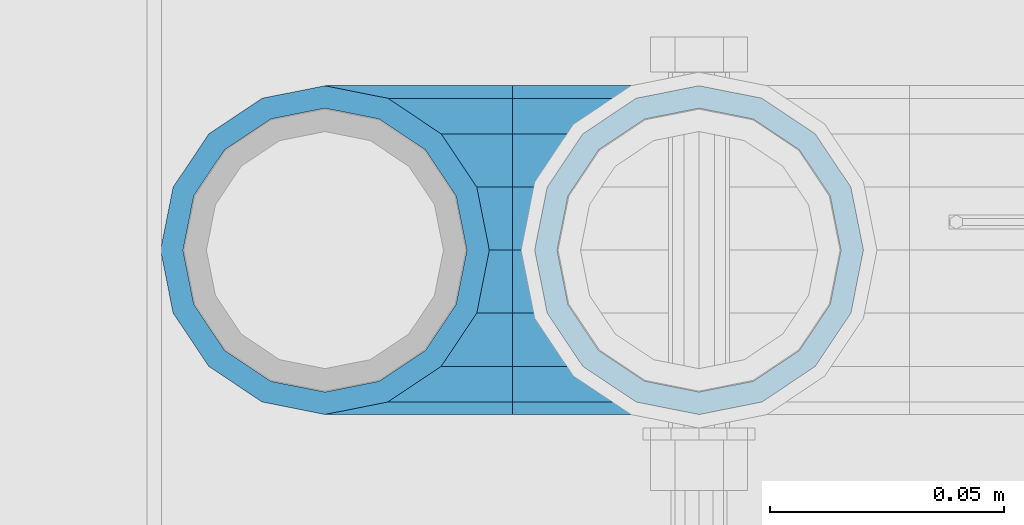
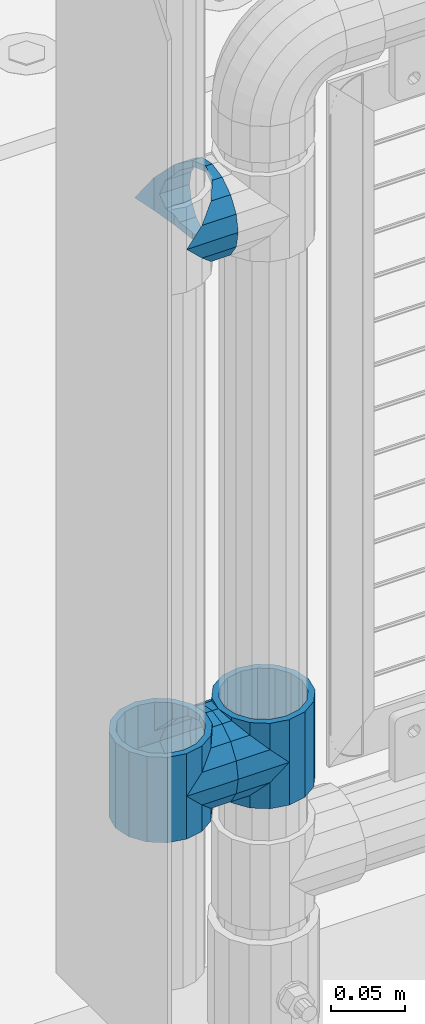
# One storey, part 158 of 270: 5 beams.
"""IFC2X3 building model written with IfcOpenShell, lengths in millimetres."""

from ifc_helpers import new_model, si_unit, frame, origin_with_axes, place, context, subcontext, project, spatial, faceted_brep, material, type_object, element, save


model = new_model("IFC2X3")

# Units and contexts
model_context = context("Model", 3, precision=1e-05, world=origin_with_axes())
body_context = subcontext(model_context, "Body", "Model", "MODEL_VIEW")
ifc_project = project(units=[si_unit("LENGTHUNIT", "METRE", prefix="MILLI"), si_unit("AREAUNIT", "SQUARE_METRE"), si_unit("VOLUMEUNIT", "CUBIC_METRE"), si_unit("MASSUNIT", "GRAM", prefix="KILO"), si_unit("TIMEUNIT", "SECOND"), si_unit("PLANEANGLEUNIT", "RADIAN"), si_unit("SOLIDANGLEUNIT", "STERADIAN"), si_unit("THERMODYNAMICTEMPERATUREUNIT", "DEGREE_CELSIUS"), si_unit("LUMINOUSINTENSITYUNIT", "LUMEN")], contexts=[model_context])

# Site, building, storey
site_placement = place(None, origin_with_axes())
site = spatial("IfcSite", under=ifc_project, at=site_placement, CompositionType="ELEMENT")
building_placement = place(site_placement, origin_with_axes())
building = spatial("IfcBuilding", under=site, at=building_placement, Name="Standard", CompositionType="ELEMENT")
storey_placement = place(building_placement, origin_with_axes())
storey = spatial("IfcBuildingStorey", under=building, at=storey_placement, Name="Undefined", CompositionType="ELEMENT", Elevation=0.0)

# Beams
ifc_material = material(Name="Misc_Undefined")
beam_type = type_object("IfcBeamType", PredefinedType="NOTDEFINED")
beam_1_placement = place(storey_placement, frame((541.0, -16335.5, 398.67), z_axis=(0.0, -1.0, 0.0), x_axis=(1.0, 0.0, 0.0)))
element("IfcBeam", 1, at=beam_1_placement, inside=storey, type_object=beam_type, material=ifc_material, context=body_context, shape_type="Brep", body=[
    faceted_brep([(0.0, 0.0, -35.1499999999996), (13.4513226476338, -13.4513226476329, -32.4743655677721), (13.4513226476338, 13.4513226476329, -32.4743655677721), (32.4743655677703, 32.4743655677717, 13.4513226476338), (32.4743655677703, 26.8123795176776, 13.4513226476338), (27.1226768591041, 21.4606908090117, 21.4606908090118), (24.8548033587067, 16.3810424080045, 24.8548033587067), (24.8548033587067, 24.8548033587072, 24.8548033587067), (13.4513226476338, 13.4513226476329, 32.4743655677721), (13.4513226476338, -13.4513226476329, 32.4743655677721), (0.0, 0.0, 35.1499999999996), (20.0882031229812, 11.6144421722805, 28.0397438117179), (16.6306603983612, 0.0, 30.3500000000004), (20.0882031229812, -11.6144421722805, 28.0397438117179), (24.8548033587067, -16.3810424080045, 24.8548033587067), (24.8548033587067, -24.8548033587072, 24.8548033587067), (32.4743655677703, -26.8123795176775, 13.4513226476338), (32.4743655677703, -32.4743655677717, 13.4513226476338), (27.1226768591041, -21.4606908090117, 21.4606908090118), (35.1500000000015, -30.35, 0.0), (35.1500000000015, -35.15, 0.0), (32.8397438117208, -28.0397438117175, 11.6144421722802), (32.8397438117172, -28.0397438117175, -11.6144421722802), (32.4743655677703, -26.8123795176776, -13.4513226476338), (32.4743655677703, -32.4743655677717, -13.4513226476338), (27.1226768591041, -21.4606908090117, -21.4606908090118), (24.8548033587067, -16.3810424080045, -24.8548033587067), (24.8548033587067, -24.8548033587072, -24.8548033587067), (20.0882031229849, -11.6144421722805, -28.0397438117179), (16.6306603983721, 0.0, -30.3500000000004), (20.0882031229849, 11.6144421722805, -28.0397438117179), (24.8548033587067, 16.3810424080045, -24.8548033587067), (24.8548033587067, 24.8548033587072, -24.8548033587067), (27.1226768591041, 21.4606908090117, -21.4606908090118), (32.4743655677703, 26.8123795176775, -13.4513226476338), (32.4743655677703, 32.4743655677717, -13.4513226476338), (32.8397438117172, 28.0397438117175, -11.6144421722802), (35.1500000000015, 30.35, 0.0), (35.1500000000015, 35.1500000000003, 0.0), (32.8397438117208, 28.0397438117175, 11.6144421722802), (40.1500000000015, -35.15, 0.0), (40.1500000000015, -32.4743655677717, 13.4513226476338), (40.1500000000015, -24.8548033587072, 24.8548033587067), (40.1500000000015, -13.4513226476329, 32.4743655677721), (40.1500000000015, 0.0, 35.1499999999996), (40.1500000000015, 13.4513226476329, 32.4743655677721), (40.1500000000015, 24.8548033587072, 24.8548033587067), (40.1500000000015, 32.4743655677717, 13.4513226476338), (40.1500000000015, 35.15, 0.0), (40.1500000000015, -24.8548033587072, -24.8548033587067), (40.1500000000015, -32.4743655677717, -13.4513226476338), (40.1500000000015, -13.4513226476329, -32.4743655677721), (40.1500000000015, 0.0, -35.1499999999996), (40.1500000000015, 13.4513226476329, -32.4743655677721), (40.1500000000015, 24.8548033587072, -24.8548033587067), (40.1500000000015, 32.4743655677717, -13.4513226476338), (40.1500000000015, -21.4606908090117, 21.4606908090118), (40.1500000000015, -11.6144421722805, 28.0397438117179), (40.1500000000015, 0.0, 30.3500000000004), (40.1500000000015, 11.6144421722805, 28.0397438117179), (40.1500000000015, 21.4606908090117, 21.4606908090118), (40.1500000000015, 28.0397438117175, 11.6144421722802), (40.1500000000015, 30.35, 0.0), (40.1500000000015, 28.0397438117175, -11.6144421722802), (40.1500000000015, 21.4606908090117, -21.4606908090118), (40.1500000000015, 11.6144421722805, -28.0397438117179), (40.1500000000015, 0.0, -30.3500000000004), (40.1500000000015, -11.6144421722805, -28.0397438117179), (40.1500000000015, -21.4606908090117, -21.4606908090118), (40.1500000000015, -28.0397438117175, -11.6144421722802), (40.1500000000015, -30.35, 0.0), (40.1500000000015, -28.0397438117175, 11.6144421722802)], [[[0, 1, 2]], [[3, 4, 5, 6, 7]], [[8, 9, 10]], [[7, 6, 11, 12, 13, 14, 15, 9, 8]], [[16, 17, 15, 14, 18]], [[19, 20, 17, 16, 21]], [[22, 23, 24, 20, 19]], [[25, 26, 27, 24, 23]], [[2, 1, 27, 26, 28, 29, 30, 31, 32]], [[32, 31, 33, 34, 35]], [[35, 34, 36, 37, 38]], [[38, 37, 39, 4, 3]], [[40, 41, 17, 20]], [[41, 42, 15, 17]], [[42, 43, 9, 15]], [[43, 44, 10, 9]], [[44, 45, 8, 10]], [[45, 46, 7, 8]], [[46, 47, 3, 7]], [[47, 48, 38, 3]], [[49, 50, 24, 27]], [[51, 49, 27, 1]], [[52, 51, 1, 0]], [[53, 52, 0, 2]], [[54, 53, 2, 32]], [[55, 54, 32, 35]], [[48, 55, 35, 38]], [[50, 40, 20, 24]], [[49, 51, 52, 53, 54, 55, 48, 47, 46, 45, 44, 43, 42, 41, 40, 50], [56, 57, 58, 59, 60, 61, 62, 63, 64, 65, 66, 67, 68, 69, 70, 71]], [[63, 62, 37, 36]], [[33, 64, 63, 36, 34]], [[30, 65, 64, 33, 31]], [[66, 65, 30, 29]], [[67, 66, 29, 28]], [[68, 67, 28, 26, 25]], [[69, 68, 25, 23, 22]], [[70, 69, 22, 19]], [[71, 70, 19, 21]], [[18, 56, 71, 21, 16]], [[13, 57, 56, 18, 14]], [[58, 57, 13, 12]], [[59, 58, 12, 11]], [[60, 59, 11, 6, 5]], [[61, 60, 5, 4, 39]], [[62, 61, 39, 37]]]),
])
beam_2_placement = place(storey_placement, frame((621.0, -16335.5, 398.67), z_axis=(0.0, 1.0, 0.0), x_axis=(-1.0, 0.0, 0.0)))
element("IfcBeam", 2, at=beam_2_placement, inside=storey, type_object=beam_type, material=ifc_material, context=body_context, shape_type="Brep", body=[
    faceted_brep([(0.0, 0.0, -35.1499999999996), (13.4513226476338, -13.4513226476329, -32.4743655677721), (13.4513226476338, 13.4513226476329, -32.4743655677721), (32.4743655677703, -26.8123795176775, 13.4513226476338), (32.4743655677703, -32.4743655677717, 13.4513226476338), (24.8548033587067, -24.8548033587072, 24.8548033587067), (24.8548033587067, -16.3810424080045, 24.8548033587067), (27.1226768591041, -21.4606908090117, 21.4606908090118), (35.1500000000015, -30.35, 0.0), (35.1500000000015, -35.15, 0.0), (32.8397438117208, -28.0397438117175, 11.6144421722802), (32.8397438117172, -28.0397438117175, -11.6144421722802), (32.4743655677703, -26.8123795176776, -13.4513226476338), (32.4743655677703, -32.4743655677717, -13.4513226476338), (27.1226768591041, -21.4606908090117, -21.4606908090118), (24.8548033587067, -16.3810424080045, -24.8548033587067), (24.8548033587067, -24.8548033587072, -24.8548033587067), (20.0882031229849, -11.6144421722805, -28.0397438117179), (16.6306603983721, 0.0, -30.3500000000004), (20.0882031229849, 11.6144421722805, -28.0397438117179), (24.8548033587067, 16.3810424080045, -24.8548033587067), (24.8548033587067, 24.8548033587072, -24.8548033587067), (27.1226768591041, 21.4606908090117, -21.4606908090118), (32.4743655677703, 26.8123795176775, -13.4513226476338), (32.4743655677703, 32.4743655677717, -13.4513226476338), (32.8397438117172, 28.0397438117175, -11.6144421722802), (35.1500000000015, 30.35, 0.0), (35.1500000000015, 35.1500000000003, 0.0), (32.8397438117208, 28.0397438117175, 11.6144421722802), (32.4743655677703, 26.8123795176776, 13.4513226476338), (32.4743655677703, 32.4743655677717, 13.4513226476338), (27.1226768591041, 21.4606908090117, 21.4606908090118), (24.8548033587067, 16.3810424080045, 24.8548033587067), (24.8548033587067, 24.8548033587072, 24.8548033587067), (13.4513226476338, 13.4513226476329, 32.4743655677721), (13.4513226476338, -13.4513226476329, 32.4743655677721), (0.0, 0.0, 35.1499999999996), (20.0882031229812, 11.6144421722805, 28.0397438117179), (16.6306603983612, 0.0, 30.3500000000004), (20.0882031229812, -11.6144421722805, 28.0397438117179), (40.1500000000015, -35.15, 0.0), (40.1500000000015, -32.4743655677717, 13.4513226476338), (40.1500000000015, -24.8548033587072, 24.8548033587067), (40.1500000000015, -13.4513226476329, 32.4743655677721), (40.1500000000015, 0.0, 35.1499999999996), (40.1500000000015, -24.8548033587072, -24.8548033587067), (40.1500000000015, -32.4743655677717, -13.4513226476338), (40.1500000000015, -13.4513226476329, -32.4743655677721), (40.1500000000015, 0.0, -35.1499999999996), (40.1500000000015, 13.4513226476329, -32.4743655677721), (40.1500000000015, 24.8548033587072, -24.8548033587067), (40.1500000000015, 32.4743655677717, -13.4513226476338), (40.1500000000015, 35.15, 0.0), (40.1500000000015, 32.4743655677717, 13.4513226476338), (40.1500000000015, 24.8548033587072, 24.8548033587067), (40.1500000000015, 13.4513226476329, 32.4743655677721), (40.1500000000015, -21.4606908090117, 21.4606908090118), (40.1500000000015, -11.6144421722805, 28.0397438117179), (40.1500000000015, 0.0, 30.3500000000004), (40.1500000000015, 11.6144421722805, 28.0397438117179), (40.1500000000015, 21.4606908090117, 21.4606908090118), (40.1500000000015, 28.0397438117175, 11.6144421722802), (40.1500000000015, 30.35, 0.0), (40.1500000000015, 28.0397438117175, -11.6144421722802), (40.1500000000015, 21.4606908090117, -21.4606908090118), (40.1500000000015, 11.6144421722805, -28.0397438117179), (40.1500000000015, 0.0, -30.3500000000004), (40.1500000000015, -11.6144421722805, -28.0397438117179), (40.1500000000015, -21.4606908090117, -21.4606908090118), (40.1500000000015, -28.0397438117175, -11.6144421722802), (40.1500000000015, -30.35, 0.0), (40.1500000000015, -28.0397438117175, 11.6144421722802)], [[[0, 1, 2]], [[3, 4, 5, 6, 7]], [[8, 9, 4, 3, 10]], [[11, 12, 13, 9, 8]], [[14, 15, 16, 13, 12]], [[2, 1, 16, 15, 17, 18, 19, 20, 21]], [[21, 20, 22, 23, 24]], [[24, 23, 25, 26, 27]], [[27, 26, 28, 29, 30]], [[30, 29, 31, 32, 33]], [[34, 35, 36]], [[33, 32, 37, 38, 39, 6, 5, 35, 34]], [[40, 41, 4, 9]], [[41, 42, 5, 4]], [[42, 43, 35, 5]], [[43, 44, 36, 35]], [[45, 46, 13, 16]], [[47, 45, 16, 1]], [[48, 47, 1, 0]], [[49, 48, 0, 2]], [[50, 49, 2, 21]], [[51, 50, 21, 24]], [[52, 51, 24, 27]], [[53, 52, 27, 30]], [[54, 53, 30, 33]], [[55, 54, 33, 34]], [[44, 55, 34, 36]], [[46, 40, 9, 13]], [[45, 47, 48, 49, 50, 51, 52, 53, 54, 55, 44, 43, 42, 41, 40, 46], [56, 57, 58, 59, 60, 61, 62, 63, 64, 65, 66, 67, 68, 69, 70, 71]], [[59, 58, 38, 37]], [[60, 59, 37, 32, 31]], [[61, 60, 31, 29, 28]], [[62, 61, 28, 26]], [[63, 62, 26, 25]], [[22, 64, 63, 25, 23]], [[19, 65, 64, 22, 20]], [[66, 65, 19, 18]], [[67, 66, 18, 17]], [[68, 67, 17, 15, 14]], [[69, 68, 14, 12, 11]], [[70, 69, 11, 8]], [[71, 70, 8, 10]], [[7, 56, 71, 10, 3]], [[39, 57, 56, 7, 6]], [[58, 57, 39, 38]]]),
])
beam_3_placement = place(storey_placement, frame((541.0, -16335.5, 433.819999999999), z_axis=(-1.0, 0.0, 0.0), x_axis=(0.0, 0.0, -1.0)))
element("IfcBeam", 3, at=beam_3_placement, inside=storey, type_object=beam_type, material=ifc_material, context=body_context, shape_type="Brep", body=[
    faceted_brep([(7.11025618828319, -11.6144421722802, -32.8397438117172), (7.11025618828319, -11.6144421722802, -28.0397438117179), (13.689309190989, -21.4606908090118, -21.46069080901), (13.689309190989, -21.4606908090118, -27.1226768591041), (8.33762048232484, -13.4513226476338, -32.4743655677703), (23.5355578277203, -28.0397438117179, -11.614442172282), (23.5355578277203, -28.0397438117179, -20.0882031229885), (18.7689575919954, -24.8548033587067, -24.8548033587067), (35.1500000000015, -30.35, 0.0), (35.1500000000008, -30.3500000000004, -16.6306603983721), (46.7644421722812, -28.0397438117179, -11.614442172282), (46.7644421722812, -28.0397438117179, -20.0882031229885), (51.5310424080071, -24.8548033587067, -24.8548033587067), (56.6106908090125, -21.4606908090118, -21.46069080901), (56.6106908090125, -21.4606908090118, -27.1226768591041), (61.9623795176767, -13.4513226476338, -32.4743655677703), (63.1897438117183, -11.6144421722802, -28.0397438117179), (63.1897438117183, -11.6144421722802, -32.8397438117172), (65.5000000000008, 0.0, -30.3499999999985), (65.5000000000008, 0.0, -35.1500000000015), (63.1897438117183, 11.6144421722802, -28.0397438117179), (63.1897438117183, 11.6144421722802, -32.8397438117208), (56.6106908090125, 21.4606908090118, -21.46069080901), (56.6106908090125, 21.4606908090118, -27.1226768591005), (61.9623795176767, 13.4513226476338, -32.4743655677703), (46.7644421722812, 28.0397438117179, -11.614442172282), (46.7644421722812, 28.0397438117179, -20.0882031229812), (51.5310424080071, 24.8548033587067, -24.8548033587067), (35.1500000000015, 30.35, 0.0), (35.1500000000008, 30.3500000000004, -16.6306603983612), (23.5355578277203, 28.0397438117179, -11.614442172282), (23.5355578277203, 28.0397438117179, -20.0882031229812), (18.7689575919954, 24.8548033587067, -24.8548033587067), (13.689309190989, 21.4606908090118, -21.46069080901), (13.689309190989, 21.4606908090118, -27.1226768591005), (8.33762048232484, 13.4513226476338, -32.4743655677703), (7.11025618828324, 11.6144421722802, -28.0397438117179), (7.11025618828324, 11.6144421722802, -32.8397438117208), (4.80000000000075, 0.0, -30.3499999999985), (4.80000000000075, 0.0, -35.1500000000015), (0.0, 21.4606908090118, 21.46069080901), (0.0, 28.0397438117179, 11.614442172282), (70.2999999999993, 28.0397438117179, 11.614442172282), (70.2999999999993, 21.4606908090118, 21.46069080901), (0.0, 11.6144421722802, 28.0397438117179), (70.2999999999993, 11.6144421722802, 28.0397438117179), (0.0, 0.0, 30.3499999999985), (70.2999999999993, 0.0, 30.3499999999985), (0.0, -11.6144421722802, 28.0397438117179), (70.2999999999993, -11.6144421722802, 28.0397438117179), (0.0, -21.4606908090118, 21.46069080901), (70.2999999999993, -21.4606908090118, 21.46069080901), (0.0, -28.0397438117179, 11.614442172282), (70.2999999999993, -28.0397438117179, 11.614442172282), (0.0, -24.8548033587067, -24.8548033587067), (0.0, -13.4513226476338, -32.4743655677703), (0.0, 0.0, -35.1499999999996), (0.0, -32.4743655677721, 13.4513226476338), (0.0, -35.1499999999996, 0.0), (70.2999999999993, -35.1499999999996, 0.0), (70.2999999999993, -32.4743655677721, 13.4513226476338), (0.0, -24.8548033587067, 24.8548033587067), (70.2999999999993, -24.8548033587067, 24.8548033587067), (0.0, -13.4513226476338, 32.4743655677703), (70.2999999999993, -13.4513226476338, 32.4743655677703), (0.0, 0.0, 35.1499999999996), (70.2999999999993, 0.0, 35.1500000000015), (0.0, 13.4513226476338, 32.4743655677703), (70.2999999999993, 13.4513226476338, 32.4743655677703), (0.0, 24.8548033587067, 24.8548033587067), (70.2999999999993, 24.8548033587067, 24.8548033587067), (0.0, 32.4743655677721, 13.4513226476338), (70.2999999999993, 32.4743655677721, 13.4513226476338), (0.0, 35.1499999999996, 0.0), (70.2999999999993, 35.1499999999996, 0.0), (0.0, 32.4743655677721, -13.4513226476338), (70.2999999999993, 32.4743655677721, -13.4513226476338), (70.2999999999993, -13.4513226476338, -32.4743655677703), (70.2999999999993, -24.8548033587067, -24.8548033587067), (70.2999999999993, 0.0, -35.1500000000015), (70.2999999999993, 13.4513226476338, -32.4743655677703), (70.2999999999993, 24.8548033587067, -24.8548033587067), (0.0, 24.8548033587067, -24.8548033587067), (0.0, 13.4513226476338, -32.4743655677703), (70.2999999999993, -32.4743655677721, -13.4513226476338), (0.0, -32.4743655677721, -13.4513226476338), (0.0, -28.0397438117179, -11.614442172282), (0.0, -21.4606908090118, -21.46069080901), (0.0, -11.6144421722802, -28.0397438117179), (0.0, 0.0, -30.3499999999985), (0.0, 11.6144421722802, -28.0397438117179), (0.0, 21.4606908090118, -21.46069080901), (0.0, 28.0397438117179, -11.614442172282), (0.0, 30.3500000000004, 0.0), (0.0, -30.3500000000004, 0.0), (70.2999999999993, 30.3500000000004, 0.0), (70.2999999999993, 28.0397438117179, -11.614442172282), (70.2999999999993, 21.4606908090118, -21.46069080901), (70.2999999999993, 11.6144421722802, -28.0397438117179), (70.2999999999993, 0.0, -30.3499999999985), (70.2999999999993, -11.6144421722802, -28.0397438117179), (70.2999999999993, -21.4606908090118, -21.46069080901), (70.2999999999993, -28.0397438117179, -11.614442172282), (70.2999999999993, -30.3500000000004, 0.0)], [[[0, 1, 2, 3, 4]], [[3, 2, 5, 6, 7]], [[6, 5, 8, 9]], [[9, 8, 10, 11]], [[12, 11, 10, 13, 14]], [[15, 14, 13, 16, 17]], [[17, 16, 18, 19]], [[19, 18, 20, 21]], [[21, 20, 22, 23, 24]], [[23, 22, 25, 26, 27]], [[26, 25, 28, 29]], [[29, 28, 30, 31]], [[32, 31, 30, 33, 34]], [[35, 34, 33, 36, 37]], [[37, 36, 38, 39]], [[39, 38, 1, 0]], [[40, 41, 42, 43]], [[44, 40, 43, 45]], [[46, 44, 45, 47]], [[48, 46, 47, 49]], [[50, 48, 49, 51]], [[52, 50, 51, 53]], [[7, 54, 55, 4, 3]], [[4, 55, 56, 39, 0]], [[57, 58, 59, 60]], [[61, 57, 60, 62]], [[63, 61, 62, 64]], [[65, 63, 64, 66]], [[67, 65, 66, 68]], [[69, 67, 68, 70]], [[71, 69, 70, 72]], [[73, 71, 72, 74]], [[75, 73, 74, 76]], [[77, 78, 12, 14, 15]], [[79, 77, 15, 17, 19]], [[24, 80, 79, 19, 21]], [[27, 81, 80, 24, 23]], [[82, 75, 76, 81, 27, 26, 29, 31, 32]], [[83, 82, 32, 34, 35]], [[56, 83, 35, 37, 39]], [[9, 11, 12, 78, 84, 85, 54, 7, 6]], [[58, 85, 84, 59]], [[57, 61, 63, 65, 67, 69, 71, 73, 75, 82, 83, 56, 55, 54, 85, 58], [86, 87, 88, 89, 90, 91, 92, 93, 41, 40, 44, 46, 48, 50, 52, 94]], [[90, 89, 38, 36]], [[91, 90, 36, 33]], [[92, 91, 33, 30]], [[93, 92, 30, 28]], [[41, 93, 28, 95, 42]], [[96, 95, 28, 25]], [[97, 96, 25, 22]], [[98, 97, 22, 20]], [[99, 98, 20, 18]], [[100, 99, 18, 16]], [[101, 100, 16, 13]], [[102, 101, 13, 10]], [[103, 102, 10, 8]], [[78, 77, 79, 80, 81, 76, 74, 72, 70, 68, 66, 64, 62, 60, 59, 84], [51, 49, 47, 45, 43, 42, 95, 96, 97, 98, 99, 100, 101, 102, 103, 53]], [[8, 94, 52, 53, 103]], [[86, 94, 8, 5]], [[87, 86, 5, 2]], [[88, 87, 2, 1]], [[89, 88, 1, 38]]]),
])
beam_4_placement = place(storey_placement, frame((621.0, -16335.5, 433.819999999999), z_axis=(1.0, 0.0, 0.0), x_axis=(0.0, 0.0, -1.0)))
element("IfcBeam", 4, at=beam_4_placement, inside=storey, type_object=beam_type, material=ifc_material, context=body_context, shape_type="Brep", body=[
    faceted_brep([(56.6106908090125, 21.4606908090118, -27.1226768591005), (56.6106908090125, 21.4606908090118, -21.46069080901), (46.7644421722812, 28.0397438117179, -11.614442172282), (46.7644421722812, 28.0397438117179, -20.0882031229812), (51.5310424080071, 24.8548033587067, -24.8548033587067), (63.1897438117183, 11.6144421722802, -32.8397438117208), (63.1897438117183, 11.6144421722802, -28.0397438117179), (61.9623795176767, 13.4513226476338, -32.4743655677703), (65.5000000000008, 0.0, -35.1500000000015), (65.5000000000008, 0.0, -30.3499999999985), (63.1897438117183, -11.6144421722802, -32.8397438117172), (63.1897438117183, -11.6144421722802, -28.0397438117179), (61.9623795176767, -13.4513226476338, -32.4743655677703), (56.6106908090125, -21.4606908090118, -27.1226768591041), (56.6106908090125, -21.4606908090118, -21.46069080901), (51.5310424080071, -24.8548033587067, -24.8548033587067), (46.7644421722812, -28.0397438117179, -20.0882031229885), (46.7644421722812, -28.0397438117179, -11.614442172282), (35.1500000000008, -30.3500000000004, -16.6306603983721), (35.1500000000015, -30.35, 0.0), (23.5355578277203, -28.0397438117179, -20.0882031229885), (23.5355578277203, -28.0397438117179, -11.614442172282), (13.689309190989, -21.4606908090118, -27.1226768591041), (13.689309190989, -21.4606908090118, -21.46069080901), (18.7689575919954, -24.8548033587067, -24.8548033587067), (7.11025618828319, -11.6144421722802, -32.8397438117172), (7.11025618828319, -11.6144421722802, -28.0397438117179), (8.33762048232484, -13.4513226476338, -32.4743655677703), (4.80000000000075, 0.0, -35.1500000000015), (4.80000000000075, 0.0, -30.3499999999985), (7.11025618828324, 11.6144421722802, -32.8397438117208), (7.11025618828324, 11.6144421722802, -28.0397438117179), (8.33762048232484, 13.4513226476338, -32.4743655677703), (13.689309190989, 21.4606908090118, -27.1226768591005), (13.689309190989, 21.4606908090118, -21.46069080901), (18.7689575919954, 24.8548033587067, -24.8548033587067), (23.5355578277203, 28.0397438117179, -20.0882031229812), (23.5355578277203, 28.0397438117179, -11.614442172282), (35.1500000000008, 30.3500000000004, -16.6306603983612), (35.1500000000015, 30.35, 0.0), (0.0, 32.4743655677721, -13.4513226476338), (0.0, 35.1499999999996, 0.0), (70.2999999999993, 35.1499999999996, 0.0), (70.2999999999993, 32.4743655677721, -13.4513226476338), (0.0, 32.4743655677721, 13.4513226476338), (70.2999999999993, 32.4743655677721, 13.4513226476338), (0.0, 24.8548033587067, 24.8548033587067), (70.2999999999993, 24.8548033587067, 24.8548033587067), (0.0, 13.4513226476338, 32.4743655677703), (70.2999999999993, 13.4513226476338, 32.4743655677703), (0.0, 0.0, 35.1499999999996), (70.2999999999993, 0.0, 35.1500000000015), (0.0, -13.4513226476338, 32.4743655677703), (70.2999999999993, -13.4513226476338, 32.4743655677703), (0.0, -24.8548033587067, 24.8548033587067), (70.2999999999993, -24.8548033587067, 24.8548033587067), (0.0, -32.4743655677721, 13.4513226476338), (70.2999999999993, -32.4743655677721, 13.4513226476338), (0.0, -35.1499999999996, 0.0), (70.2999999999993, -35.1499999999996, 0.0), (70.2999999999993, -30.3500000000004, 0.0), (70.2999999999993, -28.0397438117179, -11.614442172282), (70.2999999999993, -21.4606908090118, -21.46069080901), (70.2999999999993, -11.6144421722802, -28.0397438117179), (70.2999999999993, 0.0, -30.3499999999985), (70.2999999999993, 11.6144421722802, -28.0397438117179), (70.2999999999993, 21.4606908090118, -21.46069080901), (70.2999999999993, 28.0397438117179, -11.614442172282), (0.0, -28.0397438117179, -11.614442172282), (0.0, -30.3500000000004, 0.0), (0.0, -21.4606908090118, -21.46069080901), (0.0, -11.6144421722802, -28.0397438117179), (0.0, 0.0, -30.3499999999985), (0.0, 11.6144421722802, -28.0397438117179), (0.0, 21.4606908090118, -21.46069080901), (0.0, 28.0397438117179, -11.614442172282), (0.0, 30.3500000000004, 0.0), (70.2999999999993, 30.3500000000004, 0.0), (0.0, 28.0397438117179, 11.614442172282), (70.2999999999993, 28.0397438117179, 11.614442172282), (0.0, 21.4606908090118, 21.46069080901), (70.2999999999993, 21.4606908090118, 21.46069080901), (0.0, 11.6144421722802, 28.0397438117179), (70.2999999999993, 11.6144421722802, 28.0397438117179), (0.0, 0.0, 30.3499999999985), (70.2999999999993, 0.0, 30.3499999999985), (0.0, -11.6144421722802, 28.0397438117179), (70.2999999999993, -11.6144421722802, 28.0397438117179), (0.0, -21.4606908090118, 21.46069080901), (70.2999999999993, -21.4606908090118, 21.46069080901), (0.0, -28.0397438117179, 11.614442172282), (70.2999999999993, -28.0397438117179, 11.614442172282), (70.2999999999993, -24.8548033587067, -24.8548033587067), (70.2999999999993, -13.4513226476338, -32.4743655677703), (70.2999999999993, 0.0, -35.1500000000015), (70.2999999999993, 13.4513226476338, -32.4743655677703), (70.2999999999993, 24.8548033587067, -24.8548033587067), (70.2999999999993, -32.4743655677721, -13.4513226476338), (0.0, -32.4743655677721, -13.4513226476338), (0.0, 24.8548033587067, -24.8548033587067), (0.0, 13.4513226476338, -32.4743655677703), (0.0, 0.0, -35.1499999999996), (0.0, -13.4513226476338, -32.4743655677703), (0.0, -24.8548033587067, -24.8548033587067)], [[[0, 1, 2, 3, 4]], [[5, 6, 1, 0, 7]], [[8, 9, 6, 5]], [[10, 11, 9, 8]], [[12, 13, 14, 11, 10]], [[15, 16, 17, 14, 13]], [[18, 19, 17, 16]], [[20, 21, 19, 18]], [[22, 23, 21, 20, 24]], [[25, 26, 23, 22, 27]], [[28, 29, 26, 25]], [[30, 31, 29, 28]], [[32, 33, 34, 31, 30]], [[35, 36, 37, 34, 33]], [[38, 39, 37, 36]], [[3, 2, 39, 38]], [[40, 41, 42, 43]], [[41, 44, 45, 42]], [[44, 46, 47, 45]], [[46, 48, 49, 47]], [[48, 50, 51, 49]], [[50, 52, 53, 51]], [[52, 54, 55, 53]], [[54, 56, 57, 55]], [[56, 58, 59, 57]], [[60, 61, 17, 19]], [[61, 62, 14, 17]], [[62, 63, 11, 14]], [[63, 64, 9, 11]], [[64, 65, 6, 9]], [[65, 66, 1, 6]], [[66, 67, 2, 1]], [[68, 69, 19, 21]], [[70, 68, 21, 23]], [[71, 70, 23, 26]], [[72, 71, 26, 29]], [[73, 72, 29, 31]], [[74, 73, 31, 34]], [[75, 74, 34, 37]], [[76, 75, 37, 39]], [[67, 77, 39, 2]], [[78, 76, 39, 77, 79]], [[80, 78, 79, 81]], [[82, 80, 81, 83]], [[84, 82, 83, 85]], [[86, 84, 85, 87]], [[88, 86, 87, 89]], [[90, 88, 89, 91]], [[19, 69, 90, 91, 60]], [[92, 93, 94, 95, 96, 43, 42, 45, 47, 49, 51, 53, 55, 57, 59, 97], [89, 87, 85, 83, 81, 79, 77, 67, 66, 65, 64, 63, 62, 61, 60, 91]], [[58, 98, 97, 59]], [[56, 54, 52, 50, 48, 46, 44, 41, 40, 99, 100, 101, 102, 103, 98, 58], [68, 70, 71, 72, 73, 74, 75, 76, 78, 80, 82, 84, 86, 88, 90, 69]], [[100, 99, 35, 33, 32]], [[101, 100, 32, 30, 28]], [[27, 102, 101, 28, 25]], [[24, 103, 102, 27, 22]], [[18, 16, 15, 92, 97, 98, 103, 24, 20]], [[93, 92, 15, 13, 12]], [[94, 93, 12, 10, 8]], [[7, 95, 94, 8, 5]], [[4, 96, 95, 7, 0]], [[99, 40, 43, 96, 4, 3, 38, 36, 35]]]),
])
beam_5_placement = place(storey_placement, frame((541.0, -16335.5, 848.670000000001), z_axis=(0.0, -1.0, 0.0), x_axis=(1.0, 0.0, 0.0)))
element("IfcBeam", 5, at=beam_5_placement, inside=storey, type_object=beam_type, material=ifc_material, context=body_context, shape_type="Brep", body=[
    faceted_brep([(0.0, 0.0, -35.1499999999996), (13.4513226476338, -13.4513226476329, -32.4743655677721), (13.4513226476338, 13.4513226476329, -32.4743655677721), (32.4743655677703, 32.4743655677717, 13.4513226476338), (32.4743655677703, 26.8123795176776, 13.4513226476338), (27.1226768591041, 21.4606908090117, 21.4606908090118), (24.8548033587067, 16.3810424080045, 24.8548033587067), (24.8548033587067, 24.8548033587072, 24.8548033587067), (13.4513226476338, 13.4513226476329, 32.4743655677721), (13.4513226476338, -13.4513226476329, 32.4743655677721), (0.0, 0.0, 35.1499999999996), (20.0882031229812, 11.6144421722805, 28.0397438117179), (16.6306603983612, 0.0, 30.3500000000004), (20.0882031229812, -11.6144421722805, 28.0397438117179), (24.8548033587067, -16.3810424080045, 24.8548033587067), (24.8548033587067, -24.8548033587072, 24.8548033587067), (32.4743655677703, -26.8123795176775, 13.4513226476338), (32.4743655677703, -32.4743655677717, 13.4513226476338), (27.1226768591041, -21.4606908090117, 21.4606908090118), (35.1500000000015, -30.35, 0.0), (35.1500000000015, -35.15, 0.0), (32.8397438117208, -28.0397438117175, 11.6144421722802), (32.8397438117172, -28.0397438117175, -11.6144421722802), (32.4743655677703, -26.8123795176776, -13.4513226476338), (32.4743655677703, -32.4743655677717, -13.4513226476338), (27.1226768591041, -21.4606908090117, -21.4606908090118), (24.8548033587067, -16.3810424080045, -24.8548033587067), (24.8548033587067, -24.8548033587072, -24.8548033587067), (20.0882031229849, -11.6144421722805, -28.0397438117179), (16.6306603983721, 0.0, -30.3500000000004), (20.0882031229849, 11.6144421722805, -28.0397438117179), (24.8548033587067, 16.3810424080045, -24.8548033587067), (24.8548033587067, 24.8548033587072, -24.8548033587067), (27.1226768591041, 21.4606908090117, -21.4606908090118), (32.4743655677703, 26.8123795176775, -13.4513226476338), (32.4743655677703, 32.4743655677717, -13.4513226476338), (32.8397438117172, 28.0397438117175, -11.6144421722802), (35.1500000000015, 30.35, 0.0), (35.1500000000015, 35.1500000000003, 0.0), (32.8397438117208, 28.0397438117175, 11.6144421722802), (40.1500000000015, -35.15, 0.0), (40.1500000000015, -32.4743655677717, 13.4513226476338), (40.1500000000015, -24.8548033587072, 24.8548033587067), (40.1500000000015, -13.4513226476329, 32.4743655677721), (40.1500000000015, 0.0, 35.1499999999996), (40.1500000000015, 13.4513226476329, 32.4743655677721), (40.1500000000015, 24.8548033587072, 24.8548033587067), (40.1500000000015, 32.4743655677717, 13.4513226476338), (40.1500000000015, 35.15, 0.0), (40.1500000000015, -24.8548033587072, -24.8548033587067), (40.1500000000015, -32.4743655677717, -13.4513226476338), (40.1500000000015, -13.4513226476329, -32.4743655677721), (40.1500000000015, 0.0, -35.1499999999996), (40.1500000000015, 13.4513226476329, -32.4743655677721), (40.1500000000015, 24.8548033587072, -24.8548033587067), (40.1500000000015, 32.4743655677717, -13.4513226476338), (40.1500000000015, -21.4606908090117, 21.4606908090118), (40.1500000000015, -11.6144421722805, 28.0397438117179), (40.1500000000015, 0.0, 30.3500000000004), (40.1500000000015, 11.6144421722805, 28.0397438117179), (40.1500000000015, 21.4606908090117, 21.4606908090118), (40.1500000000015, 28.0397438117175, 11.6144421722802), (40.1500000000015, 30.35, 0.0), (40.1500000000015, 28.0397438117175, -11.6144421722802), (40.1500000000015, 21.4606908090117, -21.4606908090118), (40.1500000000015, 11.6144421722805, -28.0397438117179), (40.1500000000015, 0.0, -30.3500000000004), (40.1500000000015, -11.6144421722805, -28.0397438117179), (40.1500000000015, -21.4606908090117, -21.4606908090118), (40.1500000000015, -28.0397438117175, -11.6144421722802), (40.1500000000015, -30.35, 0.0), (40.1500000000015, -28.0397438117175, 11.6144421722802)], [[[0, 1, 2]], [[3, 4, 5, 6, 7]], [[8, 9, 10]], [[7, 6, 11, 12, 13, 14, 15, 9, 8]], [[16, 17, 15, 14, 18]], [[19, 20, 17, 16, 21]], [[22, 23, 24, 20, 19]], [[25, 26, 27, 24, 23]], [[2, 1, 27, 26, 28, 29, 30, 31, 32]], [[32, 31, 33, 34, 35]], [[35, 34, 36, 37, 38]], [[38, 37, 39, 4, 3]], [[40, 41, 17, 20]], [[41, 42, 15, 17]], [[42, 43, 9, 15]], [[43, 44, 10, 9]], [[44, 45, 8, 10]], [[45, 46, 7, 8]], [[46, 47, 3, 7]], [[47, 48, 38, 3]], [[49, 50, 24, 27]], [[51, 49, 27, 1]], [[52, 51, 1, 0]], [[53, 52, 0, 2]], [[54, 53, 2, 32]], [[55, 54, 32, 35]], [[48, 55, 35, 38]], [[50, 40, 20, 24]], [[49, 51, 52, 53, 54, 55, 48, 47, 46, 45, 44, 43, 42, 41, 40, 50], [56, 57, 58, 59, 60, 61, 62, 63, 64, 65, 66, 67, 68, 69, 70, 71]], [[63, 62, 37, 36]], [[33, 64, 63, 36, 34]], [[30, 65, 64, 33, 31]], [[66, 65, 30, 29]], [[67, 66, 29, 28]], [[68, 67, 28, 26, 25]], [[69, 68, 25, 23, 22]], [[70, 69, 22, 19]], [[71, 70, 19, 21]], [[18, 56, 71, 21, 16]], [[13, 57, 56, 18, 14]], [[58, 57, 13, 12]], [[59, 58, 12, 11]], [[60, 59, 11, 6, 5]], [[61, 60, 5, 4, 39]], [[62, 61, 39, 37]]]),
])

save(model, "model.ifc")
